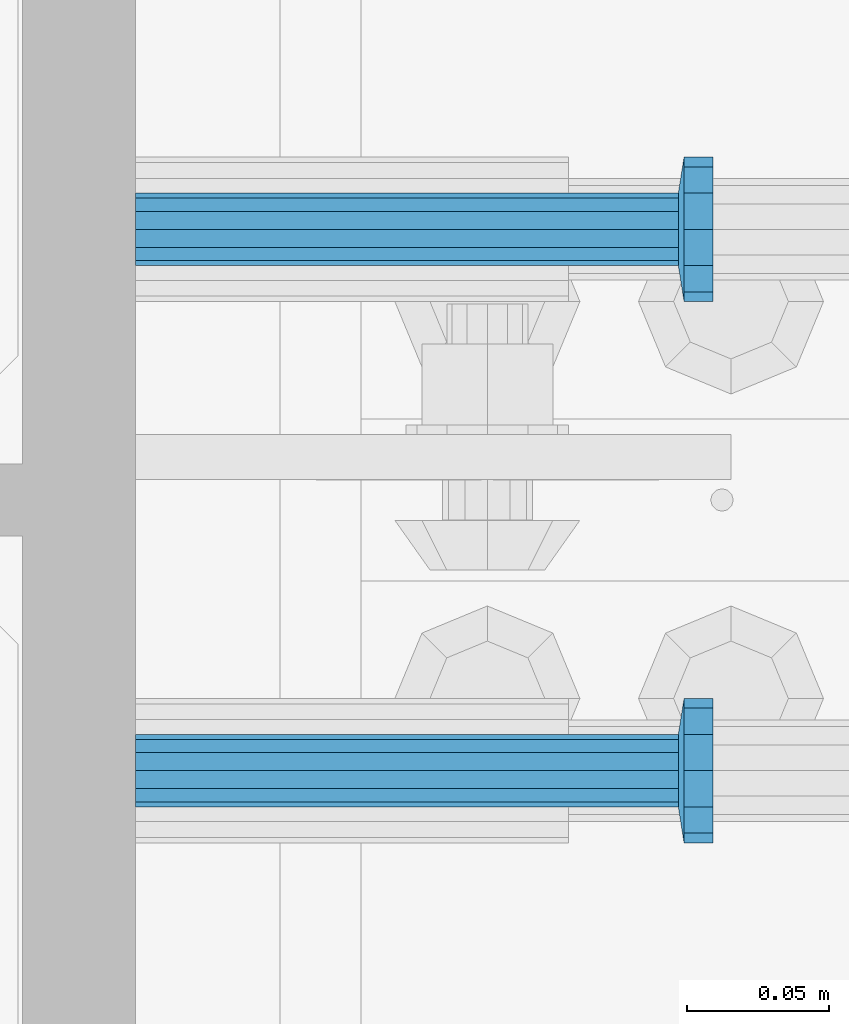
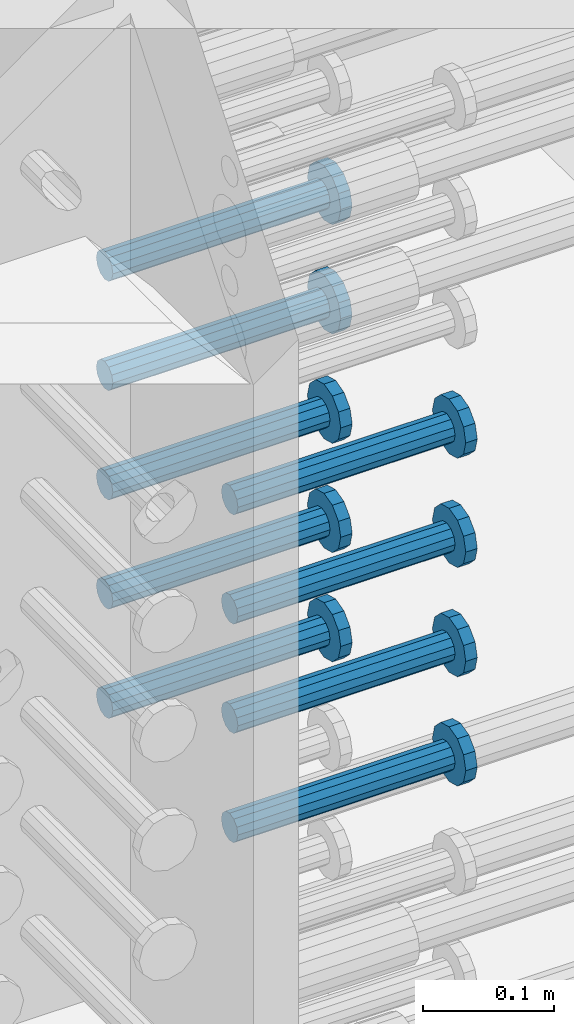
# One storey, part 1196 of 1763: 9 beams, 1 element without a shape of its own.
"""IFC2X3 building model written with IfcOpenShell, lengths in millimetres."""

from ifc_helpers import new_model, si_unit, frame, origin_with_axes, place, context, subcontext, project, spatial, faceted_brep, material, type_object, element, aggregate, save


model = new_model("IFC2X3")

# Units and contexts
model_context = context("Model", 3, precision=1e-05, world=origin_with_axes())
body_context = subcontext(model_context, "Body", "Model", "MODEL_VIEW")
ifc_project = project(units=[si_unit("LENGTHUNIT", "METRE", prefix="MILLI"), si_unit("AREAUNIT", "SQUARE_METRE"), si_unit("VOLUMEUNIT", "CUBIC_METRE"), si_unit("MASSUNIT", "GRAM", prefix="KILO"), si_unit("TIMEUNIT", "SECOND"), si_unit("PLANEANGLEUNIT", "RADIAN"), si_unit("SOLIDANGLEUNIT", "STERADIAN"), si_unit("THERMODYNAMICTEMPERATUREUNIT", "DEGREE_CELSIUS"), si_unit("LUMINOUSINTENSITYUNIT", "LUMEN")], contexts=[model_context])

# Site, building, storey
site_placement = place(None, origin_with_axes())
site = spatial("IfcSite", under=ifc_project, at=site_placement, CompositionType="ELEMENT")
building_placement = place(site_placement, origin_with_axes())
building = spatial("IfcBuilding", under=site, at=building_placement, Name="Undefined", CompositionType="ELEMENT")
storey_placement = place(building_placement, origin_with_axes())
storey = spatial("IfcBuildingStorey", under=building, at=storey_placement, Name="Undefined", CompositionType="ELEMENT", Elevation=0.0)

# Assembly, beams
assembly_placement = place(storey_placement, origin_with_axes())
assembly = element("IfcElementAssembly", 1, at=assembly_placement, inside=storey, Name="COLUMN", AssemblyPlace="NOTDEFINED", PredefinedType="RIGID_FRAME")
ifc_material = material(Name="STEEL/A108")
beam_type = type_object("IfcBeamType", PredefinedType="NOTDEFINED")
beam_1_placement = place(assembly_placement, frame((-72291.0119786597, 552.450000000834, 4724.40000000007), z_axis=(0.0, 1.0, 0.0), x_axis=(1.0, 0.0, 0.0)))
beam_1 = element("IfcBeam", 2, at=beam_1_placement, type_object=beam_type, material=ifc_material, Name="HEADED STUD ANCHOR", context=body_context, shape_type="Brep", body=[
    faceted_brep([(0.0, -12.6999999999971, -1.81898940354586e-12), (3.63797880709171e-12, -11.0, -6.34999990463257), (191.00799999576, -11.0, -6.34999990454889), (191.007999995752, -12.6999998092651, 8.36735125631094e-11), (7.27595761418343e-12, -6.34999990463257, -11.0), (191.00799999576, -6.34999990463257, -10.9999999999163), (3.63797880709171e-12, 0.0, -12.6999998092651), (191.00799999576, 0.0, -12.6999998091815), (7.27595761418343e-12, 6.34999990463257, -11.0), (191.00799999576, 6.34999990463257, -10.9999999999163), (3.63797880709171e-12, 11.0, -6.34999990463257), (191.00799999576, 11.0, -6.34999990454889), (0.0, 12.6999999999971, -1.81898940354586e-12), (191.007999995752, 12.6999998092651, 8.36735125631094e-11), (0.0, 11.0, 6.34999990463257), (191.007999995752, 11.0, 6.34999990471624), (-3.63797880709171e-12, 6.34999990463257, 11.0), (191.007999995749, 6.34999990463257, 11.0000000000837), (-3.63797880709171e-12, 0.0, 12.6999998092651), (191.007999995749, 0.0, 12.6999998093488), (-3.63797880709171e-12, -6.34999990463257, 11.0), (191.007999995749, -6.34999990463257, 11.0000000000837), (0.0, -11.0, 6.34999990463257), (191.007999995752, -11.0, 6.34999990471624), (193.039999995715, -22.0, -12.6999998091796), (193.039999995708, -25.3999996185303, 8.54925019666553e-11), (193.039999995719, -12.6999998092651, -21.9999999999145), (193.039999995719, 0.0, -25.3999996184448), (193.039999995719, 12.6999998092651, -21.9999999999145), (193.039999995715, 22.0, -12.6999998091796), (193.039999995708, 25.3999996185303, 8.54925019666553e-11), (193.039999995704, 22.0, 12.6999998093506), (193.039999995701, 12.6999998092651, 22.0000000000855), (193.039999995697, 0.0, 25.3999996186158), (193.039999995701, -12.6999998092651, 22.0000000000855), (193.039999995704, -22.0, 12.6999998093506), (203.199999995486, -22.0, -12.6999998091742), (203.199999995482, -25.3999996185303, 9.09494701772928e-11), (203.199999995493, -12.6999998092651, -21.9999999999091), (203.199999995493, 0.0, -25.3999996184393), (203.199999995493, 12.6999998092651, -21.9999999999091), (203.199999995486, 22.0, -12.6999998091742), (203.199999995482, 25.3999996185303, 9.09494701772928e-11), (203.199999995479, 22.0, 12.6999998093561), (203.199999995475, 12.6999998092651, 22.0000000000909), (203.199999995471, 0.0, 25.3999996186212), (203.199999995475, -12.6999998092651, 22.0000000000909), (203.199999995479, -22.0, 12.6999998093561)], [[[0, 1, 2, 3]], [[1, 4, 5, 2]], [[4, 6, 7, 5]], [[6, 8, 9, 7]], [[8, 10, 11, 9]], [[10, 12, 13, 11]], [[12, 14, 15, 13]], [[14, 16, 17, 15]], [[16, 18, 19, 17]], [[18, 20, 21, 19]], [[20, 22, 23, 21]], [[22, 0, 3, 23]], [[22, 20, 18, 16, 14, 12, 10, 8, 6, 4, 1, 0]], [[3, 2, 24, 25]], [[2, 5, 26, 24]], [[5, 7, 27, 26]], [[7, 9, 28, 27]], [[9, 11, 29, 28]], [[11, 13, 30, 29]], [[13, 15, 31, 30]], [[15, 17, 32, 31]], [[17, 19, 33, 32]], [[19, 21, 34, 33]], [[21, 23, 35, 34]], [[23, 3, 25, 35]], [[25, 24, 36, 37]], [[24, 26, 38, 36]], [[26, 27, 39, 38]], [[27, 28, 40, 39]], [[28, 29, 41, 40]], [[29, 30, 42, 41]], [[30, 31, 43, 42]], [[31, 32, 44, 43]], [[32, 33, 45, 44]], [[33, 34, 46, 45]], [[34, 35, 47, 46]], [[35, 25, 37, 47]], [[38, 39, 40, 41, 42, 43, 44, 45, 46, 47, 37, 36]]]),
])
beam_2_placement = place(assembly_placement, frame((-72291.0120473202, 361.950000001446, 4622.80000000005), z_axis=(0.0, 1.0, 0.0), x_axis=(1.0, 0.0, 0.0)))
beam_2 = element("IfcBeam", 3, at=beam_2_placement, type_object=beam_type, material=ifc_material, Name="HEADED STUD ANCHOR", context=body_context, shape_type="Brep", body=[
    faceted_brep([(0.0, -12.6999999999971, -1.81898940354586e-12), (3.63797880709171e-12, -11.0, -6.34999990463257), (191.00799999576, -11.0, -6.34999990454889), (191.007999995752, -12.6999998092651, 8.36735125631094e-11), (7.27595761418343e-12, -6.34999990463257, -11.0), (191.00799999576, -6.34999990463257, -10.9999999999163), (3.63797880709171e-12, 0.0, -12.6999998092651), (191.00799999576, 0.0, -12.6999998091815), (7.27595761418343e-12, 6.34999990463257, -11.0), (191.00799999576, 6.34999990463257, -10.9999999999163), (3.63797880709171e-12, 11.0, -6.34999990463257), (191.00799999576, 11.0, -6.34999990454889), (0.0, 12.6999999999971, -1.81898940354586e-12), (191.007999995752, 12.6999998092651, 8.36735125631094e-11), (0.0, 11.0, 6.34999990463257), (191.007999995752, 11.0, 6.34999990471624), (-3.63797880709171e-12, 6.34999990463257, 11.0), (191.007999995749, 6.34999990463257, 11.0000000000837), (-3.63797880709171e-12, 0.0, 12.6999998092651), (191.007999995749, 0.0, 12.6999998093488), (-3.63797880709171e-12, -6.34999990463257, 11.0), (191.007999995749, -6.34999990463257, 11.0000000000837), (0.0, -11.0, 6.34999990463257), (191.007999995752, -11.0, 6.34999990471624), (193.039999995715, -22.0, -12.6999998091796), (193.039999995708, -25.3999996185303, 8.54925019666553e-11), (193.039999995719, -12.6999998092651, -21.9999999999145), (193.039999995719, 0.0, -25.3999996184448), (193.039999995719, 12.6999998092651, -21.9999999999145), (193.039999995715, 22.0, -12.6999998091796), (193.039999995708, 25.3999996185303, 8.54925019666553e-11), (193.039999995704, 22.0, 12.6999998093506), (193.039999995701, 12.6999998092651, 22.0000000000855), (193.039999995697, 0.0, 25.3999996186158), (193.039999995701, -12.6999998092651, 22.0000000000855), (193.039999995704, -22.0, 12.6999998093506), (203.199999995486, -22.0, -12.6999998091742), (203.199999995482, -25.3999996185303, 9.09494701772928e-11), (203.199999995493, -12.6999998092651, -21.9999999999091), (203.199999995493, 0.0, -25.3999996184393), (203.199999995493, 12.6999998092651, -21.9999999999091), (203.199999995486, 22.0, -12.6999998091742), (203.199999995482, 25.3999996185303, 9.09494701772928e-11), (203.199999995479, 22.0, 12.6999998093561), (203.199999995475, 12.6999998092651, 22.0000000000909), (203.199999995471, 0.0, 25.3999996186212), (203.199999995475, -12.6999998092651, 22.0000000000909), (203.199999995479, -22.0, 12.6999998093561)], [[[0, 1, 2, 3]], [[1, 4, 5, 2]], [[4, 6, 7, 5]], [[6, 8, 9, 7]], [[8, 10, 11, 9]], [[10, 12, 13, 11]], [[12, 14, 15, 13]], [[14, 16, 17, 15]], [[16, 18, 19, 17]], [[18, 20, 21, 19]], [[20, 22, 23, 21]], [[22, 0, 3, 23]], [[22, 20, 18, 16, 14, 12, 10, 8, 6, 4, 1, 0]], [[3, 2, 24, 25]], [[2, 5, 26, 24]], [[5, 7, 27, 26]], [[7, 9, 28, 27]], [[9, 11, 29, 28]], [[11, 13, 30, 29]], [[13, 15, 31, 30]], [[15, 17, 32, 31]], [[17, 19, 33, 32]], [[19, 21, 34, 33]], [[21, 23, 35, 34]], [[23, 3, 25, 35]], [[25, 24, 36, 37]], [[24, 26, 38, 36]], [[26, 27, 39, 38]], [[27, 28, 40, 39]], [[28, 29, 41, 40]], [[29, 30, 42, 41]], [[30, 31, 43, 42]], [[31, 32, 44, 43]], [[32, 33, 45, 44]], [[33, 34, 46, 45]], [[34, 35, 47, 46]], [[35, 25, 37, 47]], [[38, 39, 40, 41, 42, 43, 44, 45, 46, 47, 37, 36]]]),
])
beam_3_placement = place(assembly_placement, frame((-72291.0119786597, 552.450000000834, 4622.80000000005), z_axis=(0.0, 1.0, 0.0), x_axis=(1.0, 0.0, 0.0)))
beam_3 = element("IfcBeam", 4, at=beam_3_placement, type_object=beam_type, material=ifc_material, Name="HEADED STUD ANCHOR", context=body_context, shape_type="Brep", body=[
    faceted_brep([(0.0, -12.6999999999971, -1.81898940354586e-12), (3.63797880709171e-12, -11.0, -6.34999990463257), (191.00799999576, -11.0, -6.34999990454889), (191.007999995752, -12.6999998092651, 8.36735125631094e-11), (7.27595761418343e-12, -6.34999990463257, -11.0), (191.00799999576, -6.34999990463257, -10.9999999999163), (3.63797880709171e-12, 0.0, -12.6999998092651), (191.00799999576, 0.0, -12.6999998091815), (7.27595761418343e-12, 6.34999990463257, -11.0), (191.00799999576, 6.34999990463257, -10.9999999999163), (3.63797880709171e-12, 11.0, -6.34999990463257), (191.00799999576, 11.0, -6.34999990454889), (0.0, 12.6999999999971, -1.81898940354586e-12), (191.007999995752, 12.6999998092651, 8.36735125631094e-11), (0.0, 11.0, 6.34999990463257), (191.007999995752, 11.0, 6.34999990471624), (-3.63797880709171e-12, 6.34999990463257, 11.0), (191.007999995749, 6.34999990463257, 11.0000000000837), (-3.63797880709171e-12, 0.0, 12.6999998092651), (191.007999995749, 0.0, 12.6999998093488), (-3.63797880709171e-12, -6.34999990463257, 11.0), (191.007999995749, -6.34999990463257, 11.0000000000837), (0.0, -11.0, 6.34999990463257), (191.007999995752, -11.0, 6.34999990471624), (193.039999995715, -22.0, -12.6999998091796), (193.039999995708, -25.3999996185303, 8.54925019666553e-11), (193.039999995719, -12.6999998092651, -21.9999999999145), (193.039999995719, 0.0, -25.3999996184448), (193.039999995719, 12.6999998092651, -21.9999999999145), (193.039999995715, 22.0, -12.6999998091796), (193.039999995708, 25.3999996185303, 8.54925019666553e-11), (193.039999995704, 22.0, 12.6999998093506), (193.039999995701, 12.6999998092651, 22.0000000000855), (193.039999995697, 0.0, 25.3999996186158), (193.039999995701, -12.6999998092651, 22.0000000000855), (193.039999995704, -22.0, 12.6999998093506), (203.199999995486, -22.0, -12.6999998091742), (203.199999995482, -25.3999996185303, 9.09494701772928e-11), (203.199999995493, -12.6999998092651, -21.9999999999091), (203.199999995493, 0.0, -25.3999996184393), (203.199999995493, 12.6999998092651, -21.9999999999091), (203.199999995486, 22.0, -12.6999998091742), (203.199999995482, 25.3999996185303, 9.09494701772928e-11), (203.199999995479, 22.0, 12.6999998093561), (203.199999995475, 12.6999998092651, 22.0000000000909), (203.199999995471, 0.0, 25.3999996186212), (203.199999995475, -12.6999998092651, 22.0000000000909), (203.199999995479, -22.0, 12.6999998093561)], [[[0, 1, 2, 3]], [[1, 4, 5, 2]], [[4, 6, 7, 5]], [[6, 8, 9, 7]], [[8, 10, 11, 9]], [[10, 12, 13, 11]], [[12, 14, 15, 13]], [[14, 16, 17, 15]], [[16, 18, 19, 17]], [[18, 20, 21, 19]], [[20, 22, 23, 21]], [[22, 0, 3, 23]], [[22, 20, 18, 16, 14, 12, 10, 8, 6, 4, 1, 0]], [[3, 2, 24, 25]], [[2, 5, 26, 24]], [[5, 7, 27, 26]], [[7, 9, 28, 27]], [[9, 11, 29, 28]], [[11, 13, 30, 29]], [[13, 15, 31, 30]], [[15, 17, 32, 31]], [[17, 19, 33, 32]], [[19, 21, 34, 33]], [[21, 23, 35, 34]], [[23, 3, 25, 35]], [[25, 24, 36, 37]], [[24, 26, 38, 36]], [[26, 27, 39, 38]], [[27, 28, 40, 39]], [[28, 29, 41, 40]], [[29, 30, 42, 41]], [[30, 31, 43, 42]], [[31, 32, 44, 43]], [[32, 33, 45, 44]], [[33, 34, 46, 45]], [[34, 35, 47, 46]], [[35, 25, 37, 47]], [[38, 39, 40, 41, 42, 43, 44, 45, 46, 47, 37, 36]]]),
])
beam_4_placement = place(assembly_placement, frame((-72291.0120473202, 361.950000001446, 4521.20000000005), z_axis=(0.0, 1.0, 0.0), x_axis=(1.0, 0.0, 0.0)))
beam_4 = element("IfcBeam", 5, at=beam_4_placement, type_object=beam_type, material=ifc_material, Name="HEADED STUD ANCHOR", context=body_context, shape_type="Brep", body=[
    faceted_brep([(0.0, -12.6999999999971, -1.81898940354586e-12), (3.63797880709171e-12, -11.0, -6.34999990463257), (191.00799999576, -11.0, -6.34999990454889), (191.007999995752, -12.6999998092651, 8.36735125631094e-11), (7.27595761418343e-12, -6.34999990463257, -11.0), (191.00799999576, -6.34999990463257, -10.9999999999163), (3.63797880709171e-12, 0.0, -12.6999998092651), (191.00799999576, 0.0, -12.6999998091815), (7.27595761418343e-12, 6.34999990463257, -11.0), (191.00799999576, 6.34999990463257, -10.9999999999163), (3.63797880709171e-12, 11.0, -6.34999990463257), (191.00799999576, 11.0, -6.34999990454889), (0.0, 12.6999999999971, -1.81898940354586e-12), (191.007999995752, 12.6999998092651, 8.36735125631094e-11), (0.0, 11.0, 6.34999990463257), (191.007999995752, 11.0, 6.34999990471624), (-3.63797880709171e-12, 6.34999990463257, 11.0), (191.007999995749, 6.34999990463257, 11.0000000000837), (-3.63797880709171e-12, 0.0, 12.6999998092651), (191.007999995749, 0.0, 12.6999998093488), (-3.63797880709171e-12, -6.34999990463257, 11.0), (191.007999995749, -6.34999990463257, 11.0000000000837), (0.0, -11.0, 6.34999990463257), (191.007999995752, -11.0, 6.34999990471624), (193.039999995715, -22.0, -12.6999998091796), (193.039999995708, -25.3999996185303, 8.54925019666553e-11), (193.039999995719, -12.6999998092651, -21.9999999999145), (193.039999995719, 0.0, -25.3999996184448), (193.039999995719, 12.6999998092651, -21.9999999999145), (193.039999995715, 22.0, -12.6999998091796), (193.039999995708, 25.3999996185303, 8.54925019666553e-11), (193.039999995704, 22.0, 12.6999998093506), (193.039999995701, 12.6999998092651, 22.0000000000855), (193.039999995697, 0.0, 25.3999996186158), (193.039999995701, -12.6999998092651, 22.0000000000855), (193.039999995704, -22.0, 12.6999998093506), (203.199999995486, -22.0, -12.6999998091742), (203.199999995482, -25.3999996185303, 9.09494701772928e-11), (203.199999995493, -12.6999998092651, -21.9999999999091), (203.199999995493, 0.0, -25.3999996184393), (203.199999995493, 12.6999998092651, -21.9999999999091), (203.199999995486, 22.0, -12.6999998091742), (203.199999995482, 25.3999996185303, 9.09494701772928e-11), (203.199999995479, 22.0, 12.6999998093561), (203.199999995475, 12.6999998092651, 22.0000000000909), (203.199999995471, 0.0, 25.3999996186212), (203.199999995475, -12.6999998092651, 22.0000000000909), (203.199999995479, -22.0, 12.6999998093561)], [[[0, 1, 2, 3]], [[1, 4, 5, 2]], [[4, 6, 7, 5]], [[6, 8, 9, 7]], [[8, 10, 11, 9]], [[10, 12, 13, 11]], [[12, 14, 15, 13]], [[14, 16, 17, 15]], [[16, 18, 19, 17]], [[18, 20, 21, 19]], [[20, 22, 23, 21]], [[22, 0, 3, 23]], [[22, 20, 18, 16, 14, 12, 10, 8, 6, 4, 1, 0]], [[3, 2, 24, 25]], [[2, 5, 26, 24]], [[5, 7, 27, 26]], [[7, 9, 28, 27]], [[9, 11, 29, 28]], [[11, 13, 30, 29]], [[13, 15, 31, 30]], [[15, 17, 32, 31]], [[17, 19, 33, 32]], [[19, 21, 34, 33]], [[21, 23, 35, 34]], [[23, 3, 25, 35]], [[25, 24, 36, 37]], [[24, 26, 38, 36]], [[26, 27, 39, 38]], [[27, 28, 40, 39]], [[28, 29, 41, 40]], [[29, 30, 42, 41]], [[30, 31, 43, 42]], [[31, 32, 44, 43]], [[32, 33, 45, 44]], [[33, 34, 46, 45]], [[34, 35, 47, 46]], [[35, 25, 37, 47]], [[38, 39, 40, 41, 42, 43, 44, 45, 46, 47, 37, 36]]]),
])
beam_5_placement = place(assembly_placement, frame((-72291.0119786597, 552.450000000834, 4521.20000000005), z_axis=(0.0, 1.0, 0.0), x_axis=(1.0, 0.0, 0.0)))
beam_5 = element("IfcBeam", 6, at=beam_5_placement, type_object=beam_type, material=ifc_material, Name="HEADED STUD ANCHOR", context=body_context, shape_type="Brep", body=[
    faceted_brep([(0.0, -12.6999999999971, -1.81898940354586e-12), (3.63797880709171e-12, -11.0, -6.34999990463257), (191.00799999576, -11.0, -6.34999990454889), (191.007999995752, -12.6999998092651, 8.36735125631094e-11), (7.27595761418343e-12, -6.34999990463257, -11.0), (191.00799999576, -6.34999990463257, -10.9999999999163), (3.63797880709171e-12, 0.0, -12.6999998092651), (191.00799999576, 0.0, -12.6999998091815), (7.27595761418343e-12, 6.34999990463257, -11.0), (191.00799999576, 6.34999990463257, -10.9999999999163), (3.63797880709171e-12, 11.0, -6.34999990463257), (191.00799999576, 11.0, -6.34999990454889), (0.0, 12.6999999999971, -1.81898940354586e-12), (191.007999995752, 12.6999998092651, 8.36735125631094e-11), (0.0, 11.0, 6.34999990463257), (191.007999995752, 11.0, 6.34999990471624), (-3.63797880709171e-12, 6.34999990463257, 11.0), (191.007999995749, 6.34999990463257, 11.0000000000837), (-3.63797880709171e-12, 0.0, 12.6999998092651), (191.007999995749, 0.0, 12.6999998093488), (-3.63797880709171e-12, -6.34999990463257, 11.0), (191.007999995749, -6.34999990463257, 11.0000000000837), (0.0, -11.0, 6.34999990463257), (191.007999995752, -11.0, 6.34999990471624), (193.039999995715, -22.0, -12.6999998091796), (193.039999995708, -25.3999996185303, 8.54925019666553e-11), (193.039999995719, -12.6999998092651, -21.9999999999145), (193.039999995719, 0.0, -25.3999996184448), (193.039999995719, 12.6999998092651, -21.9999999999145), (193.039999995715, 22.0, -12.6999998091796), (193.039999995708, 25.3999996185303, 8.54925019666553e-11), (193.039999995704, 22.0, 12.6999998093506), (193.039999995701, 12.6999998092651, 22.0000000000855), (193.039999995697, 0.0, 25.3999996186158), (193.039999995701, -12.6999998092651, 22.0000000000855), (193.039999995704, -22.0, 12.6999998093506), (203.199999995486, -22.0, -12.6999998091742), (203.199999995482, -25.3999996185303, 9.09494701772928e-11), (203.199999995493, -12.6999998092651, -21.9999999999091), (203.199999995493, 0.0, -25.3999996184393), (203.199999995493, 12.6999998092651, -21.9999999999091), (203.199999995486, 22.0, -12.6999998091742), (203.199999995482, 25.3999996185303, 9.09494701772928e-11), (203.199999995479, 22.0, 12.6999998093561), (203.199999995475, 12.6999998092651, 22.0000000000909), (203.199999995471, 0.0, 25.3999996186212), (203.199999995475, -12.6999998092651, 22.0000000000909), (203.199999995479, -22.0, 12.6999998093561)], [[[0, 1, 2, 3]], [[1, 4, 5, 2]], [[4, 6, 7, 5]], [[6, 8, 9, 7]], [[8, 10, 11, 9]], [[10, 12, 13, 11]], [[12, 14, 15, 13]], [[14, 16, 17, 15]], [[16, 18, 19, 17]], [[18, 20, 21, 19]], [[20, 22, 23, 21]], [[22, 0, 3, 23]], [[22, 20, 18, 16, 14, 12, 10, 8, 6, 4, 1, 0]], [[3, 2, 24, 25]], [[2, 5, 26, 24]], [[5, 7, 27, 26]], [[7, 9, 28, 27]], [[9, 11, 29, 28]], [[11, 13, 30, 29]], [[13, 15, 31, 30]], [[15, 17, 32, 31]], [[17, 19, 33, 32]], [[19, 21, 34, 33]], [[21, 23, 35, 34]], [[23, 3, 25, 35]], [[25, 24, 36, 37]], [[24, 26, 38, 36]], [[26, 27, 39, 38]], [[27, 28, 40, 39]], [[28, 29, 41, 40]], [[29, 30, 42, 41]], [[30, 31, 43, 42]], [[31, 32, 44, 43]], [[32, 33, 45, 44]], [[33, 34, 46, 45]], [[34, 35, 47, 46]], [[35, 25, 37, 47]], [[38, 39, 40, 41, 42, 43, 44, 45, 46, 47, 37, 36]]]),
])
beam_6_placement = place(assembly_placement, frame((-72291.0120473202, 361.950000001446, 4419.60000000004), z_axis=(0.0, 1.0, 0.0), x_axis=(1.0, 0.0, 0.0)))
beam_6 = element("IfcBeam", 7, at=beam_6_placement, type_object=beam_type, material=ifc_material, Name="HEADED STUD ANCHOR", context=body_context, shape_type="Brep", body=[
    faceted_brep([(0.0, -12.6999999999971, -1.81898940354586e-12), (3.63797880709171e-12, -11.0, -6.34999990463257), (191.00799999576, -11.0, -6.34999990454889), (191.007999995752, -12.6999998092651, 8.36735125631094e-11), (7.27595761418343e-12, -6.34999990463257, -11.0), (191.00799999576, -6.34999990463257, -10.9999999999163), (3.63797880709171e-12, 0.0, -12.6999998092651), (191.00799999576, 0.0, -12.6999998091815), (7.27595761418343e-12, 6.34999990463257, -11.0), (191.00799999576, 6.34999990463257, -10.9999999999163), (3.63797880709171e-12, 11.0, -6.34999990463257), (191.00799999576, 11.0, -6.34999990454889), (0.0, 12.6999999999971, -1.81898940354586e-12), (191.007999995752, 12.6999998092651, 8.36735125631094e-11), (0.0, 11.0, 6.34999990463257), (191.007999995752, 11.0, 6.34999990471624), (-3.63797880709171e-12, 6.34999990463257, 11.0), (191.007999995749, 6.34999990463257, 11.0000000000837), (-3.63797880709171e-12, 0.0, 12.6999998092651), (191.007999995749, 0.0, 12.6999998093488), (-3.63797880709171e-12, -6.34999990463257, 11.0), (191.007999995749, -6.34999990463257, 11.0000000000837), (0.0, -11.0, 6.34999990463257), (191.007999995752, -11.0, 6.34999990471624), (193.039999995715, -22.0, -12.6999998091796), (193.039999995708, -25.3999996185303, 8.54925019666553e-11), (193.039999995719, -12.6999998092651, -21.9999999999145), (193.039999995719, 0.0, -25.3999996184448), (193.039999995719, 12.6999998092651, -21.9999999999145), (193.039999995715, 22.0, -12.6999998091796), (193.039999995708, 25.3999996185303, 8.54925019666553e-11), (193.039999995704, 22.0, 12.6999998093506), (193.039999995701, 12.6999998092651, 22.0000000000855), (193.039999995697, 0.0, 25.3999996186158), (193.039999995701, -12.6999998092651, 22.0000000000855), (193.039999995704, -22.0, 12.6999998093506), (203.199999995486, -22.0, -12.6999998091742), (203.199999995482, -25.3999996185303, 9.09494701772928e-11), (203.199999995493, -12.6999998092651, -21.9999999999091), (203.199999995493, 0.0, -25.3999996184393), (203.199999995493, 12.6999998092651, -21.9999999999091), (203.199999995486, 22.0, -12.6999998091742), (203.199999995482, 25.3999996185303, 9.09494701772928e-11), (203.199999995479, 22.0, 12.6999998093561), (203.199999995475, 12.6999998092651, 22.0000000000909), (203.199999995471, 0.0, 25.3999996186212), (203.199999995475, -12.6999998092651, 22.0000000000909), (203.199999995479, -22.0, 12.6999998093561)], [[[0, 1, 2, 3]], [[1, 4, 5, 2]], [[4, 6, 7, 5]], [[6, 8, 9, 7]], [[8, 10, 11, 9]], [[10, 12, 13, 11]], [[12, 14, 15, 13]], [[14, 16, 17, 15]], [[16, 18, 19, 17]], [[18, 20, 21, 19]], [[20, 22, 23, 21]], [[22, 0, 3, 23]], [[22, 20, 18, 16, 14, 12, 10, 8, 6, 4, 1, 0]], [[3, 2, 24, 25]], [[2, 5, 26, 24]], [[5, 7, 27, 26]], [[7, 9, 28, 27]], [[9, 11, 29, 28]], [[11, 13, 30, 29]], [[13, 15, 31, 30]], [[15, 17, 32, 31]], [[17, 19, 33, 32]], [[19, 21, 34, 33]], [[21, 23, 35, 34]], [[23, 3, 25, 35]], [[25, 24, 36, 37]], [[24, 26, 38, 36]], [[26, 27, 39, 38]], [[27, 28, 40, 39]], [[28, 29, 41, 40]], [[29, 30, 42, 41]], [[30, 31, 43, 42]], [[31, 32, 44, 43]], [[32, 33, 45, 44]], [[33, 34, 46, 45]], [[34, 35, 47, 46]], [[35, 25, 37, 47]], [[38, 39, 40, 41, 42, 43, 44, 45, 46, 47, 37, 36]]]),
])
beam_7_placement = place(assembly_placement, frame((-72291.0119786597, 552.450000000834, 4419.60000000004), z_axis=(0.0, 1.0, 0.0), x_axis=(1.0, 0.0, 0.0)))
beam_7 = element("IfcBeam", 8, at=beam_7_placement, type_object=beam_type, material=ifc_material, Name="HEADED STUD ANCHOR", context=body_context, shape_type="Brep", body=[
    faceted_brep([(0.0, -12.6999999999971, -1.81898940354586e-12), (3.63797880709171e-12, -11.0, -6.34999990463257), (191.00799999576, -11.0, -6.34999990454889), (191.007999995752, -12.6999998092651, 8.36735125631094e-11), (7.27595761418343e-12, -6.34999990463257, -11.0), (191.00799999576, -6.34999990463257, -10.9999999999163), (3.63797880709171e-12, 0.0, -12.6999998092651), (191.00799999576, 0.0, -12.6999998091815), (7.27595761418343e-12, 6.34999990463257, -11.0), (191.00799999576, 6.34999990463257, -10.9999999999163), (3.63797880709171e-12, 11.0, -6.34999990463257), (191.00799999576, 11.0, -6.34999990454889), (0.0, 12.6999999999971, -1.81898940354586e-12), (191.007999995752, 12.6999998092651, 8.36735125631094e-11), (0.0, 11.0, 6.34999990463257), (191.007999995752, 11.0, 6.34999990471624), (-3.63797880709171e-12, 6.34999990463257, 11.0), (191.007999995749, 6.34999990463257, 11.0000000000837), (-3.63797880709171e-12, 0.0, 12.6999998092651), (191.007999995749, 0.0, 12.6999998093488), (-3.63797880709171e-12, -6.34999990463257, 11.0), (191.007999995749, -6.34999990463257, 11.0000000000837), (0.0, -11.0, 6.34999990463257), (191.007999995752, -11.0, 6.34999990471624), (193.039999995715, -22.0, -12.6999998091796), (193.039999995708, -25.3999996185303, 8.54925019666553e-11), (193.039999995719, -12.6999998092651, -21.9999999999145), (193.039999995719, 0.0, -25.3999996184448), (193.039999995719, 12.6999998092651, -21.9999999999145), (193.039999995715, 22.0, -12.6999998091796), (193.039999995708, 25.3999996185303, 8.54925019666553e-11), (193.039999995704, 22.0, 12.6999998093506), (193.039999995701, 12.6999998092651, 22.0000000000855), (193.039999995697, 0.0, 25.3999996186158), (193.039999995701, -12.6999998092651, 22.0000000000855), (193.039999995704, -22.0, 12.6999998093506), (203.199999995486, -22.0, -12.6999998091742), (203.199999995482, -25.3999996185303, 9.09494701772928e-11), (203.199999995493, -12.6999998092651, -21.9999999999091), (203.199999995493, 0.0, -25.3999996184393), (203.199999995493, 12.6999998092651, -21.9999999999091), (203.199999995486, 22.0, -12.6999998091742), (203.199999995482, 25.3999996185303, 9.09494701772928e-11), (203.199999995479, 22.0, 12.6999998093561), (203.199999995475, 12.6999998092651, 22.0000000000909), (203.199999995471, 0.0, 25.3999996186212), (203.199999995475, -12.6999998092651, 22.0000000000909), (203.199999995479, -22.0, 12.6999998093561)], [[[0, 1, 2, 3]], [[1, 4, 5, 2]], [[4, 6, 7, 5]], [[6, 8, 9, 7]], [[8, 10, 11, 9]], [[10, 12, 13, 11]], [[12, 14, 15, 13]], [[14, 16, 17, 15]], [[16, 18, 19, 17]], [[18, 20, 21, 19]], [[20, 22, 23, 21]], [[22, 0, 3, 23]], [[22, 20, 18, 16, 14, 12, 10, 8, 6, 4, 1, 0]], [[3, 2, 24, 25]], [[2, 5, 26, 24]], [[5, 7, 27, 26]], [[7, 9, 28, 27]], [[9, 11, 29, 28]], [[11, 13, 30, 29]], [[13, 15, 31, 30]], [[15, 17, 32, 31]], [[17, 19, 33, 32]], [[19, 21, 34, 33]], [[21, 23, 35, 34]], [[23, 3, 25, 35]], [[25, 24, 36, 37]], [[24, 26, 38, 36]], [[26, 27, 39, 38]], [[27, 28, 40, 39]], [[28, 29, 41, 40]], [[29, 30, 42, 41]], [[30, 31, 43, 42]], [[31, 32, 44, 43]], [[32, 33, 45, 44]], [[33, 34, 46, 45]], [[34, 35, 47, 46]], [[35, 25, 37, 47]], [[38, 39, 40, 41, 42, 43, 44, 45, 46, 47, 37, 36]]]),
])
beam_8_placement = place(assembly_placement, frame((-72291.0120473202, 361.950000001446, 4318.00000000004), z_axis=(0.0, 1.0, 0.0), x_axis=(1.0, 0.0, 0.0)))
beam_8 = element("IfcBeam", 9, at=beam_8_placement, type_object=beam_type, material=ifc_material, Name="HEADED STUD ANCHOR", context=body_context, shape_type="Brep", body=[
    faceted_brep([(0.0, -12.6999999999971, -1.81898940354586e-12), (3.63797880709171e-12, -11.0, -6.34999990463257), (191.00799999576, -11.0, -6.34999990454889), (191.007999995752, -12.6999998092651, 8.36735125631094e-11), (7.27595761418343e-12, -6.34999990463257, -11.0), (191.00799999576, -6.34999990463257, -10.9999999999163), (3.63797880709171e-12, 0.0, -12.6999998092651), (191.00799999576, 0.0, -12.6999998091815), (7.27595761418343e-12, 6.34999990463257, -11.0), (191.00799999576, 6.34999990463257, -10.9999999999163), (3.63797880709171e-12, 11.0, -6.34999990463257), (191.00799999576, 11.0, -6.34999990454889), (0.0, 12.6999999999971, -1.81898940354586e-12), (191.007999995752, 12.6999998092651, 8.36735125631094e-11), (0.0, 11.0, 6.34999990463257), (191.007999995752, 11.0, 6.34999990471624), (-3.63797880709171e-12, 6.34999990463257, 11.0), (191.007999995749, 6.34999990463257, 11.0000000000837), (-3.63797880709171e-12, 0.0, 12.6999998092651), (191.007999995749, 0.0, 12.6999998093488), (-3.63797880709171e-12, -6.34999990463257, 11.0), (191.007999995749, -6.34999990463257, 11.0000000000837), (0.0, -11.0, 6.34999990463257), (191.007999995752, -11.0, 6.34999990471624), (193.039999995715, -22.0, -12.6999998091796), (193.039999995708, -25.3999996185303, 8.54925019666553e-11), (193.039999995719, -12.6999998092651, -21.9999999999145), (193.039999995719, 0.0, -25.3999996184448), (193.039999995719, 12.6999998092651, -21.9999999999145), (193.039999995715, 22.0, -12.6999998091796), (193.039999995708, 25.3999996185303, 8.54925019666553e-11), (193.039999995704, 22.0, 12.6999998093506), (193.039999995701, 12.6999998092651, 22.0000000000855), (193.039999995697, 0.0, 25.3999996186158), (193.039999995701, -12.6999998092651, 22.0000000000855), (193.039999995704, -22.0, 12.6999998093506), (203.199999995486, -22.0, -12.6999998091742), (203.199999995482, -25.3999996185303, 9.09494701772928e-11), (203.199999995493, -12.6999998092651, -21.9999999999091), (203.199999995493, 0.0, -25.3999996184393), (203.199999995493, 12.6999998092651, -21.9999999999091), (203.199999995486, 22.0, -12.6999998091742), (203.199999995482, 25.3999996185303, 9.09494701772928e-11), (203.199999995479, 22.0, 12.6999998093561), (203.199999995475, 12.6999998092651, 22.0000000000909), (203.199999995471, 0.0, 25.3999996186212), (203.199999995475, -12.6999998092651, 22.0000000000909), (203.199999995479, -22.0, 12.6999998093561)], [[[0, 1, 2, 3]], [[1, 4, 5, 2]], [[4, 6, 7, 5]], [[6, 8, 9, 7]], [[8, 10, 11, 9]], [[10, 12, 13, 11]], [[12, 14, 15, 13]], [[14, 16, 17, 15]], [[16, 18, 19, 17]], [[18, 20, 21, 19]], [[20, 22, 23, 21]], [[22, 0, 3, 23]], [[22, 20, 18, 16, 14, 12, 10, 8, 6, 4, 1, 0]], [[3, 2, 24, 25]], [[2, 5, 26, 24]], [[5, 7, 27, 26]], [[7, 9, 28, 27]], [[9, 11, 29, 28]], [[11, 13, 30, 29]], [[13, 15, 31, 30]], [[15, 17, 32, 31]], [[17, 19, 33, 32]], [[19, 21, 34, 33]], [[21, 23, 35, 34]], [[23, 3, 25, 35]], [[25, 24, 36, 37]], [[24, 26, 38, 36]], [[26, 27, 39, 38]], [[27, 28, 40, 39]], [[28, 29, 41, 40]], [[29, 30, 42, 41]], [[30, 31, 43, 42]], [[31, 32, 44, 43]], [[32, 33, 45, 44]], [[33, 34, 46, 45]], [[34, 35, 47, 46]], [[35, 25, 37, 47]], [[38, 39, 40, 41, 42, 43, 44, 45, 46, 47, 37, 36]]]),
])
beam_9_placement = place(assembly_placement, frame((-72291.0119786597, 552.450000000834, 4318.00000000004), z_axis=(0.0, 1.0, 0.0), x_axis=(1.0, 0.0, 0.0)))
beam_9 = element("IfcBeam", 10, at=beam_9_placement, type_object=beam_type, material=ifc_material, Name="HEADED STUD ANCHOR", context=body_context, shape_type="Brep", body=[
    faceted_brep([(0.0, -12.6999999999971, -1.81898940354586e-12), (3.63797880709171e-12, -11.0, -6.34999990463257), (191.00799999576, -11.0, -6.34999990454889), (191.007999995752, -12.6999998092651, 8.36735125631094e-11), (7.27595761418343e-12, -6.34999990463257, -11.0), (191.00799999576, -6.34999990463257, -10.9999999999163), (3.63797880709171e-12, 0.0, -12.6999998092651), (191.00799999576, 0.0, -12.6999998091815), (7.27595761418343e-12, 6.34999990463257, -11.0), (191.00799999576, 6.34999990463257, -10.9999999999163), (3.63797880709171e-12, 11.0, -6.34999990463257), (191.00799999576, 11.0, -6.34999990454889), (0.0, 12.6999999999971, -1.81898940354586e-12), (191.007999995752, 12.6999998092651, 8.36735125631094e-11), (0.0, 11.0, 6.34999990463257), (191.007999995752, 11.0, 6.34999990471624), (-3.63797880709171e-12, 6.34999990463257, 11.0), (191.007999995749, 6.34999990463257, 11.0000000000837), (-3.63797880709171e-12, 0.0, 12.6999998092651), (191.007999995749, 0.0, 12.6999998093488), (-3.63797880709171e-12, -6.34999990463257, 11.0), (191.007999995749, -6.34999990463257, 11.0000000000837), (0.0, -11.0, 6.34999990463257), (191.007999995752, -11.0, 6.34999990471624), (193.039999995715, -22.0, -12.6999998091796), (193.039999995708, -25.3999996185303, 8.54925019666553e-11), (193.039999995719, -12.6999998092651, -21.9999999999145), (193.039999995719, 0.0, -25.3999996184448), (193.039999995719, 12.6999998092651, -21.9999999999145), (193.039999995715, 22.0, -12.6999998091796), (193.039999995708, 25.3999996185303, 8.54925019666553e-11), (193.039999995704, 22.0, 12.6999998093506), (193.039999995701, 12.6999998092651, 22.0000000000855), (193.039999995697, 0.0, 25.3999996186158), (193.039999995701, -12.6999998092651, 22.0000000000855), (193.039999995704, -22.0, 12.6999998093506), (203.199999995486, -22.0, -12.6999998091742), (203.199999995482, -25.3999996185303, 9.09494701772928e-11), (203.199999995493, -12.6999998092651, -21.9999999999091), (203.199999995493, 0.0, -25.3999996184393), (203.199999995493, 12.6999998092651, -21.9999999999091), (203.199999995486, 22.0, -12.6999998091742), (203.199999995482, 25.3999996185303, 9.09494701772928e-11), (203.199999995479, 22.0, 12.6999998093561), (203.199999995475, 12.6999998092651, 22.0000000000909), (203.199999995471, 0.0, 25.3999996186212), (203.199999995475, -12.6999998092651, 22.0000000000909), (203.199999995479, -22.0, 12.6999998093561)], [[[0, 1, 2, 3]], [[1, 4, 5, 2]], [[4, 6, 7, 5]], [[6, 8, 9, 7]], [[8, 10, 11, 9]], [[10, 12, 13, 11]], [[12, 14, 15, 13]], [[14, 16, 17, 15]], [[16, 18, 19, 17]], [[18, 20, 21, 19]], [[20, 22, 23, 21]], [[22, 0, 3, 23]], [[22, 20, 18, 16, 14, 12, 10, 8, 6, 4, 1, 0]], [[3, 2, 24, 25]], [[2, 5, 26, 24]], [[5, 7, 27, 26]], [[7, 9, 28, 27]], [[9, 11, 29, 28]], [[11, 13, 30, 29]], [[13, 15, 31, 30]], [[15, 17, 32, 31]], [[17, 19, 33, 32]], [[19, 21, 34, 33]], [[21, 23, 35, 34]], [[23, 3, 25, 35]], [[25, 24, 36, 37]], [[24, 26, 38, 36]], [[26, 27, 39, 38]], [[27, 28, 40, 39]], [[28, 29, 41, 40]], [[29, 30, 42, 41]], [[30, 31, 43, 42]], [[31, 32, 44, 43]], [[32, 33, 45, 44]], [[33, 34, 46, 45]], [[34, 35, 47, 46]], [[35, 25, 37, 47]], [[38, 39, 40, 41, 42, 43, 44, 45, 46, 47, 37, 36]]]),
])
aggregate(assembly, [beam_1, beam_2, beam_3, beam_4, beam_5, beam_6, beam_7, beam_8, beam_9])

save(model, "model.ifc")
